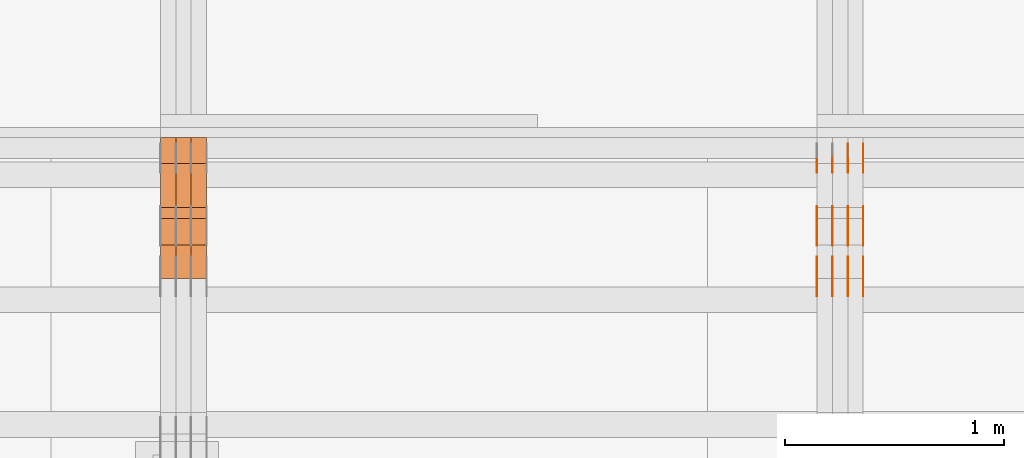
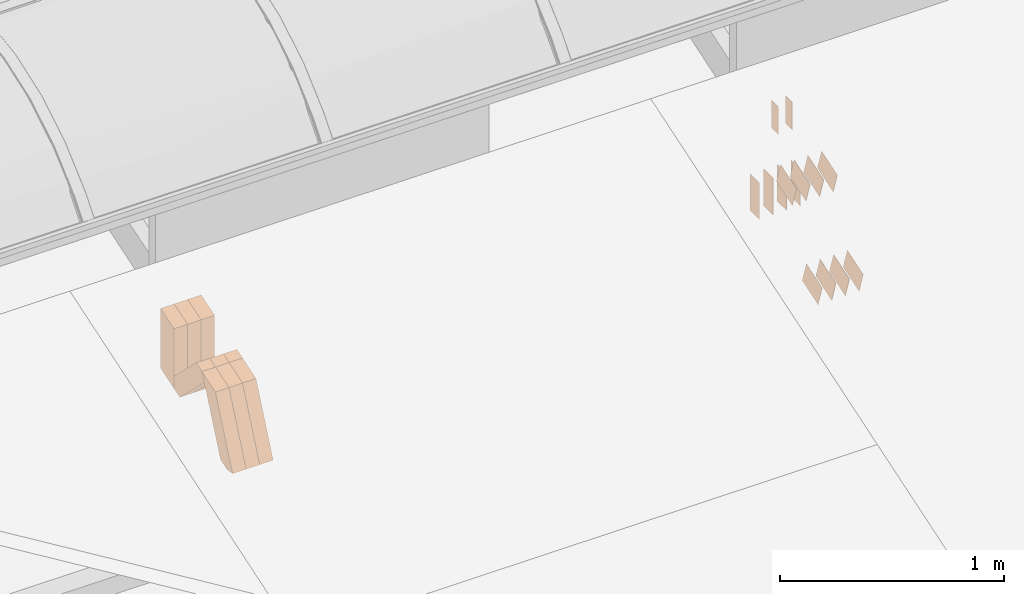
# One storey, part 97 of 385: 29 proxies.
"""IFC2X3 building model written with IfcOpenShell, lengths in millimetres."""

from ifc_helpers import new_model, entity, si_unit, converted_unit, derived_unit, direction, frame, frame_2d, origin, origin_2d_with_axis, place, context, subcontext, project, spatial, polyline, rectangle, outline, extrude, source, transform, mapped, material, type_object, type_shapes, element, save


model = new_model("IFC2X3")

# Units and contexts
model_context = context("Model", 3, precision=0.01, world=origin(), true_north=direction((6.12303176911189e-17, 1.0)))
body_context = subcontext(model_context, "Body", "Model", "MODEL_VIEW")
ifc_project = project(units=[si_unit("LENGTHUNIT", "METRE", prefix="MILLI"), si_unit("AREAUNIT", "SQUARE_METRE"), si_unit("VOLUMEUNIT", "CUBIC_METRE"), converted_unit("PLANEANGLEUNIT", "DEGREE", entity("IfcRatioMeasure", 0.0174532925199433), si_unit("PLANEANGLEUNIT", "RADIAN"), dimensions=[0, 0, 0, 0, 0, 0, 0]), si_unit("MASSUNIT", "GRAM", prefix="KILO"), derived_unit("MASSDENSITYUNIT", [(si_unit("MASSUNIT", "GRAM", prefix="KILO"), 1), (si_unit("LENGTHUNIT", "METRE"), -3)]), si_unit("TIMEUNIT", "SECOND"), si_unit("FREQUENCYUNIT", "HERTZ"), si_unit("THERMODYNAMICTEMPERATUREUNIT", "DEGREE_CELSIUS"), derived_unit("THERMALTRANSMITTANCEUNIT", [(si_unit("MASSUNIT", "GRAM", prefix="KILO"), 1), (si_unit("THERMODYNAMICTEMPERATUREUNIT", "KELVIN"), -1), (si_unit("TIMEUNIT", "SECOND"), -3)]), derived_unit("VOLUMETRICFLOWRATEUNIT", [(si_unit("LENGTHUNIT", "METRE"), 3), (si_unit("TIMEUNIT", "SECOND"), -1)]), si_unit("ELECTRICCURRENTUNIT", "AMPERE"), si_unit("ELECTRICVOLTAGEUNIT", "VOLT"), si_unit("POWERUNIT", "WATT"), si_unit("FORCEUNIT", "NEWTON", prefix="KILO"), si_unit("ILLUMINANCEUNIT", "LUX"), si_unit("LUMINOUSFLUXUNIT", "LUMEN"), si_unit("LUMINOUSINTENSITYUNIT", "CANDELA"), derived_unit("USERDEFINED", [(si_unit("MASSUNIT", "GRAM", prefix="KILO"), -1), (si_unit("LENGTHUNIT", "METRE"), -2), (si_unit("TIMEUNIT", "SECOND"), 3), (si_unit("LUMINOUSFLUXUNIT", "LUMEN"), 1)]), derived_unit("LINEARVELOCITYUNIT", [(si_unit("LENGTHUNIT", "METRE"), 1), (si_unit("TIMEUNIT", "SECOND"), -1)]), si_unit("PRESSUREUNIT", "PASCAL"), derived_unit("USERDEFINED", [(si_unit("LENGTHUNIT", "METRE"), -2), (si_unit("MASSUNIT", "GRAM", prefix="KILO"), 1), (si_unit("TIMEUNIT", "SECOND"), -2)])], contexts=[model_context])

# Site, building, storey
site_placement = place(None, origin())
site = spatial("IfcSite", under=ifc_project, at=site_placement, CompositionType="ELEMENT")
building_placement = place(site_placement, origin())
building = spatial("IfcBuilding", under=site, at=building_placement, CompositionType="ELEMENT")
storey_placement = place(building_placement, origin())
storey = spatial("IfcBuildingStorey", under=building, at=storey_placement, Name="Default", CompositionType="ELEMENT", Elevation=0.0)

# Proxies
ifc_material_1 = material(Name="IfcSurfaceStyle #209140")
building_element_proxy_type_1 = type_object("IfcBuildingElementProxyType", PredefinedType="NOTDEFINED", material=ifc_material_1)
shared_shape_1 = source(origin(), body_context, "Body", "SweptSolid", [
    extrude(rectangle(XDim=200.0, YDim=84.0, at=frame_2d((0.0, -7.105427357601e-15), x_axis=(1.0, 0.0))), frame((100.0, 42.0, 0.0), z_axis=(0.0, 0.0, 1.0), x_axis=(-1.0, 0.0, 0.0)), (0.0, 0.0, 1.0), 1.3),
])
type_shapes(building_element_proxy_type_1, [shared_shape_1])
proxy_1_placement = place(building_placement, frame((15386.3, 13702.0, 3651.4150390625), z_axis=(-1.0, 0.0, 0.0), x_axis=(0.0, 0.0, -1.0)))
element("IfcBuildingElementProxy", 1, at=proxy_1_placement, inside=storey, type_object=building_element_proxy_type_1, material=ifc_material_1, context=body_context, shape_type="MappedRepresentation", body=[
    mapped(shared_shape_1, transform((0.0, 0.0, 0.0), scale=1.0)),
])
ifc_material_2 = material(Name="IfcSurfaceStyle #209083")
building_element_proxy_type_2 = type_object("IfcBuildingElementProxyType", PredefinedType="NOTDEFINED", material=ifc_material_2)
shared_shape_2 = source(origin(), body_context, "Body", "SweptSolid", [
    extrude(rectangle(XDim=200.0, YDim=84.0, at=frame_2d((0.0, -7.105427357601e-15), x_axis=(1.0, 0.0))), frame((100.0, 42.0, 0.0), z_axis=(0.0, 0.0, 1.0), x_axis=(-1.0, 0.0, 0.0)), (0.0, 0.0, 1.0), 1.3),
])
type_shapes(building_element_proxy_type_2, [shared_shape_2])
proxy_2_placement = place(building_placement, frame((15315.0, 13702.0, 3651.4150390625), z_axis=(-1.0, 0.0, 0.0), x_axis=(0.0, 0.0, -1.0)))
element("IfcBuildingElementProxy", 2, at=proxy_2_placement, inside=storey, type_object=building_element_proxy_type_2, material=ifc_material_2, context=body_context, shape_type="MappedRepresentation", body=[
    mapped(shared_shape_2, transform((0.0, 0.0, 0.0), scale=1.0)),
])
ifc_material_3 = material(Name="IfcSurfaceStyle #209026")
building_element_proxy_type_3 = type_object("IfcBuildingElementProxyType", PredefinedType="NOTDEFINED", material=ifc_material_3)
shared_shape_3 = source(origin(), body_context, "Body", "SweptSolid", [
    extrude(rectangle(XDim=200.0, YDim=84.0, at=frame_2d((0.0, -7.105427357601e-15), x_axis=(1.0, 0.0))), frame((100.0, 42.0, 0.0), z_axis=(0.0, 0.0, 1.0), x_axis=(-1.0, 0.0, 0.0)), (0.0, 0.0, 1.0), 1.3),
])
type_shapes(building_element_proxy_type_3, [shared_shape_3])
proxy_3_placement = place(building_placement, frame((15316.3, 13702.0, 3651.4150390625), z_axis=(-1.0, 0.0, 0.0), x_axis=(0.0, 0.0, -1.0)))
element("IfcBuildingElementProxy", 3, at=proxy_3_placement, inside=storey, type_object=building_element_proxy_type_3, material=ifc_material_3, context=body_context, shape_type="MappedRepresentation", body=[
    mapped(shared_shape_3, transform((0.0, 0.0, 0.0), scale=1.0)),
])
ifc_material_4 = material(Name="IfcSurfaceStyle #208969")
building_element_proxy_type_4 = type_object("IfcBuildingElementProxyType", PredefinedType="NOTDEFINED", material=ifc_material_4)
shared_shape_4 = source(origin(), body_context, "Body", "SweptSolid", [
    extrude(rectangle(XDim=200.0, YDim=84.0, at=frame_2d((0.0, -7.105427357601e-15), x_axis=(1.0, 0.0))), frame((100.0, 42.0, 0.0), z_axis=(0.0, 0.0, 1.0), x_axis=(-1.0, 0.0, 0.0)), (0.0, 0.0, 1.0), 1.29999999999998),
])
type_shapes(building_element_proxy_type_4, [shared_shape_4])
proxy_4_placement = place(building_placement, frame((15245.0, 13702.0, 3651.4150390625), z_axis=(-1.0, 0.0, 0.0), x_axis=(0.0, 0.0, -1.0)))
element("IfcBuildingElementProxy", 4, at=proxy_4_placement, inside=storey, type_object=building_element_proxy_type_4, material=ifc_material_4, context=body_context, shape_type="MappedRepresentation", body=[
    mapped(shared_shape_4, transform((0.0, 0.0, 0.0), scale=1.0)),
])
ifc_material_5 = material(Name="IfcSurfaceStyle #208912")
building_element_proxy_type_5 = type_object("IfcBuildingElementProxyType", PredefinedType="NOTDEFINED", material=ifc_material_5)
shared_shape_5 = source(origin(), body_context, "Body", "SweptSolid", [
    extrude(rectangle(XDim=200.0, YDim=84.0, at=frame_2d((0.0, -7.105427357601e-15), x_axis=(1.0, 0.0))), frame((100.0, 42.0, 0.0), z_axis=(0.0, 0.0, 1.0), x_axis=(-1.0, 0.0, 0.0)), (0.0, 0.0, 1.0), 1.29999999999998),
])
type_shapes(building_element_proxy_type_5, [shared_shape_5])
proxy_5_placement = place(building_placement, frame((15246.3, 13702.0, 3651.4150390625), z_axis=(-1.0, 0.0, 0.0), x_axis=(0.0, 0.0, -1.0)))
element("IfcBuildingElementProxy", 5, at=proxy_5_placement, inside=storey, type_object=building_element_proxy_type_5, material=ifc_material_5, context=body_context, shape_type="MappedRepresentation", body=[
    mapped(shared_shape_5, transform((0.0, 0.0, 0.0), scale=1.0)),
])
ifc_material_6 = material(Name="IfcSurfaceStyle #208855")
building_element_proxy_type_6 = type_object("IfcBuildingElementProxyType", PredefinedType="NOTDEFINED", material=ifc_material_6)
shared_shape_6 = source(origin(), body_context, "Body", "SweptSolid", [
    extrude(rectangle(XDim=200.0, YDim=84.0, at=frame_2d((0.0, -7.105427357601e-15), x_axis=(1.0, 0.0))), frame((100.0, 42.0, 0.0), z_axis=(0.0, 0.0, 1.0), x_axis=(-1.0, 0.0, 0.0)), (0.0, 0.0, 1.0), 1.29999999999999),
])
type_shapes(building_element_proxy_type_6, [shared_shape_6])
proxy_6_placement = place(building_placement, frame((15175.0, 13702.0, 3651.4150390625), z_axis=(-1.0, 0.0, 0.0), x_axis=(0.0, 0.0, -1.0)))
element("IfcBuildingElementProxy", 6, at=proxy_6_placement, inside=storey, type_object=building_element_proxy_type_6, material=ifc_material_6, context=body_context, shape_type="MappedRepresentation", body=[
    mapped(shared_shape_6, transform((0.0, 0.0, 0.0), scale=1.0)),
])
ifc_material_7 = material(Name="IfcSurfaceStyle #208798")
building_element_proxy_type_7 = type_object("IfcBuildingElementProxyType", PredefinedType="NOTDEFINED", material=ifc_material_7)
shared_shape_7 = source(origin(), body_context, "Body", "SweptSolid", [
    extrude(outline(polyline([(-75.0003398116828, -59.9998507501386), (75.0003249421766, -59.9998507501386), (75.0003398116837, 59.9998507501387), (-75.0003249421775, 59.9998507501387), (-75.0003398116828, -59.9998507501386)])), frame((75.0003398116837, 60.0000773549637, 0.0), z_axis=(0.0, 0.0, 1.0), x_axis=(-1.0, 0.0, 0.0)), (0.0, 0.0, 1.0), 1.3),
])
type_shapes(building_element_proxy_type_7, [shared_shape_7])
proxy_7_placement = place(building_placement, frame((15386.3, 13054.73046875, 3417.8388671875), z_axis=(-1.0, 0.0, 0.0), x_axis=(0.0, 0.951056516295124, 0.309016994375039)))
element("IfcBuildingElementProxy", 7, at=proxy_7_placement, inside=storey, type_object=building_element_proxy_type_7, material=ifc_material_7, context=body_context, shape_type="MappedRepresentation", body=[
    mapped(shared_shape_7, transform((0.0, 0.0, 0.0), scale=1.0)),
])
ifc_material_8 = material(Name="IfcSurfaceStyle #208741")
building_element_proxy_type_8 = type_object("IfcBuildingElementProxyType", PredefinedType="NOTDEFINED", material=ifc_material_8)
shared_shape_8 = source(origin(), body_context, "Body", "SweptSolid", [
    extrude(outline(polyline([(-75.0003398116828, -59.9998507501386), (75.0003249421766, -59.9998507501386), (75.0003398116837, 59.9998507501387), (-75.0003249421775, 59.9998507501387), (-75.0003398116828, -59.9998507501386)])), frame((75.0003398116837, 60.0000773549637, 0.0), z_axis=(0.0, 0.0, 1.0), x_axis=(-1.0, 0.0, 0.0)), (0.0, 0.0, 1.0), 1.3),
])
type_shapes(building_element_proxy_type_8, [shared_shape_8])
proxy_8_placement = place(building_placement, frame((15315.0, 13054.73046875, 3417.8388671875), z_axis=(-1.0, 0.0, 0.0), x_axis=(0.0, 0.951056516295124, 0.309016994375039)))
element("IfcBuildingElementProxy", 8, at=proxy_8_placement, inside=storey, type_object=building_element_proxy_type_8, material=ifc_material_8, context=body_context, shape_type="MappedRepresentation", body=[
    mapped(shared_shape_8, transform((0.0, 0.0, 0.0), scale=1.0)),
])
ifc_material_9 = material(Name="IfcSurfaceStyle #208684")
building_element_proxy_type_9 = type_object("IfcBuildingElementProxyType", PredefinedType="NOTDEFINED", material=ifc_material_9)
shared_shape_9 = source(origin(), body_context, "Body", "SweptSolid", [
    extrude(outline(polyline([(-75.0003398116828, -59.9998507501386), (75.0003249421766, -59.9998507501386), (75.0003398116837, 59.9998507501387), (-75.0003249421775, 59.9998507501387), (-75.0003398116828, -59.9998507501386)])), frame((75.0003398116837, 60.0000773549637, 0.0), z_axis=(0.0, 0.0, 1.0), x_axis=(-1.0, 0.0, 0.0)), (0.0, 0.0, 1.0), 1.3),
])
type_shapes(building_element_proxy_type_9, [shared_shape_9])
proxy_9_placement = place(building_placement, frame((15316.3, 13054.73046875, 3417.8388671875), z_axis=(-1.0, 0.0, 0.0), x_axis=(0.0, 0.951056516295124, 0.309016994375039)))
element("IfcBuildingElementProxy", 9, at=proxy_9_placement, inside=storey, type_object=building_element_proxy_type_9, material=ifc_material_9, context=body_context, shape_type="MappedRepresentation", body=[
    mapped(shared_shape_9, transform((0.0, 0.0, 0.0), scale=1.0)),
])
ifc_material_10 = material(Name="IfcSurfaceStyle #208627")
building_element_proxy_type_10 = type_object("IfcBuildingElementProxyType", PredefinedType="NOTDEFINED", material=ifc_material_10)
shared_shape_10 = source(origin(), body_context, "Body", "SweptSolid", [
    extrude(outline(polyline([(-75.0003398116828, -59.9998507501386), (75.0003249421766, -59.9998507501386), (75.0003398116837, 59.9998507501387), (-75.0003249421775, 59.9998507501387), (-75.0003398116828, -59.9998507501386)])), frame((75.0003398116837, 60.0000773549637, 0.0), z_axis=(0.0, 0.0, 1.0), x_axis=(-1.0, 0.0, 0.0)), (0.0, 0.0, 1.0), 1.29999999999999),
])
type_shapes(building_element_proxy_type_10, [shared_shape_10])
proxy_10_placement = place(building_placement, frame((15245.0, 13054.73046875, 3417.8388671875), z_axis=(-1.0, 0.0, 0.0), x_axis=(0.0, 0.951056516295124, 0.309016994375039)))
element("IfcBuildingElementProxy", 10, at=proxy_10_placement, inside=storey, type_object=building_element_proxy_type_10, material=ifc_material_10, context=body_context, shape_type="MappedRepresentation", body=[
    mapped(shared_shape_10, transform((0.0, 0.0, 0.0), scale=1.0)),
])
ifc_material_11 = material(Name="IfcSurfaceStyle #208570")
building_element_proxy_type_11 = type_object("IfcBuildingElementProxyType", PredefinedType="NOTDEFINED", material=ifc_material_11)
shared_shape_11 = source(origin(), body_context, "Body", "SweptSolid", [
    extrude(outline(polyline([(-75.0003398116828, -59.9998507501386), (75.0003249421766, -59.9998507501386), (75.0003398116837, 59.9998507501387), (-75.0003249421775, 59.9998507501387), (-75.0003398116828, -59.9998507501386)])), frame((75.0003398116837, 60.0000773549637, 0.0), z_axis=(0.0, 0.0, 1.0), x_axis=(-1.0, 0.0, 0.0)), (0.0, 0.0, 1.0), 1.29999999999999),
])
type_shapes(building_element_proxy_type_11, [shared_shape_11])
proxy_11_placement = place(building_placement, frame((15246.3, 13054.73046875, 3417.8388671875), z_axis=(-1.0, 0.0, 0.0), x_axis=(0.0, 0.951056516295124, 0.309016994375039)))
element("IfcBuildingElementProxy", 11, at=proxy_11_placement, inside=storey, type_object=building_element_proxy_type_11, material=ifc_material_11, context=body_context, shape_type="MappedRepresentation", body=[
    mapped(shared_shape_11, transform((0.0, 0.0, 0.0), scale=1.0)),
])
ifc_material_12 = material(Name="IfcSurfaceStyle #208513")
building_element_proxy_type_12 = type_object("IfcBuildingElementProxyType", PredefinedType="NOTDEFINED", material=ifc_material_12)
shared_shape_12 = source(origin(), body_context, "Body", "SweptSolid", [
    extrude(outline(polyline([(-75.0003398116828, -59.9998507501386), (75.0003249421766, -59.9998507501386), (75.0003398116837, 59.9998507501387), (-75.0003249421775, 59.9998507501387), (-75.0003398116828, -59.9998507501386)])), frame((75.0003398116837, 60.0000773549637, 0.0), z_axis=(0.0, 0.0, 1.0), x_axis=(-1.0, 0.0, 0.0)), (0.0, 0.0, 1.0), 1.29999999999999),
])
type_shapes(building_element_proxy_type_12, [shared_shape_12])
proxy_12_placement = place(building_placement, frame((15175.0, 13054.73046875, 3417.8388671875), z_axis=(-1.0, 0.0, 0.0), x_axis=(0.0, 0.951056516295124, 0.309016994375039)))
element("IfcBuildingElementProxy", 12, at=proxy_12_placement, inside=storey, type_object=building_element_proxy_type_12, material=ifc_material_12, context=body_context, shape_type="MappedRepresentation", body=[
    mapped(shared_shape_12, transform((0.0, 0.0, 0.0), scale=1.0)),
])
ifc_material_13 = material(Name="IfcSurfaceStyle #200932")
building_element_proxy_type_13 = type_object("IfcBuildingElementProxyType", PredefinedType="NOTDEFINED", material=ifc_material_13)
shared_shape_13 = source(origin(), body_context, "Body", "SweptSolid", [
    extrude(outline(polyline([(-74.999875428623, -60.0000016373506), (74.9998605591059, -60.0000016373506), (74.9998754286239, 60.0000016373506), (-74.9998605591068, 60.0000016373506), (-74.999875428623, -60.0000016373506)])), frame((75.0002691827262, 60.0000190504561, 0.0), z_axis=(0.0, 0.0, 1.0), x_axis=(-1.0, 0.0, 0.0)), (0.0, 0.0, 1.0), 1.3),
])
type_shapes(building_element_proxy_type_13, [shared_shape_13])
proxy_13_placement = place(building_placement, frame((15386.3, 13285.0865109705, 3819.37496637467), z_axis=(-1.0, 0.0, 0.0), x_axis=(0.0, 0.951056516295154, 0.309016994374948)))
element("IfcBuildingElementProxy", 13, at=proxy_13_placement, inside=storey, type_object=building_element_proxy_type_13, material=ifc_material_13, context=body_context, shape_type="MappedRepresentation", body=[
    mapped(shared_shape_13, transform((0.0, 0.0, 0.0), scale=1.0)),
])
ifc_material_14 = material(Name="IfcSurfaceStyle #200875")
building_element_proxy_type_14 = type_object("IfcBuildingElementProxyType", PredefinedType="NOTDEFINED", material=ifc_material_14)
shared_shape_14 = source(origin(), body_context, "Body", "SweptSolid", [
    extrude(outline(polyline([(-74.999875428623, -60.0000016373506), (74.9998605591059, -60.0000016373506), (74.9998754286239, 60.0000016373506), (-74.9998605591068, 60.0000016373506), (-74.999875428623, -60.0000016373506)])), frame((75.0002691827262, 60.0000190504561, 0.0), z_axis=(0.0, 0.0, 1.0), x_axis=(-1.0, 0.0, 0.0)), (0.0, 0.0, 1.0), 1.3),
])
type_shapes(building_element_proxy_type_14, [shared_shape_14])
proxy_14_placement = place(building_placement, frame((15315.0, 13285.0865109705, 3819.37496637467), z_axis=(-1.0, 0.0, 0.0), x_axis=(0.0, 0.951056516295154, 0.309016994374948)))
element("IfcBuildingElementProxy", 14, at=proxy_14_placement, inside=storey, type_object=building_element_proxy_type_14, material=ifc_material_14, context=body_context, shape_type="MappedRepresentation", body=[
    mapped(shared_shape_14, transform((0.0, 0.0, 0.0), scale=1.0)),
])
ifc_material_15 = material(Name="IfcSurfaceStyle #200818")
building_element_proxy_type_15 = type_object("IfcBuildingElementProxyType", PredefinedType="NOTDEFINED", material=ifc_material_15)
shared_shape_15 = source(origin(), body_context, "Body", "SweptSolid", [
    extrude(outline(polyline([(-74.999875428623, -60.0000016373506), (74.9998605591059, -60.0000016373506), (74.9998754286239, 60.0000016373506), (-74.9998605591068, 60.0000016373506), (-74.999875428623, -60.0000016373506)])), frame((75.0002691827262, 60.0000190504561, 0.0), z_axis=(0.0, 0.0, 1.0), x_axis=(-1.0, 0.0, 0.0)), (0.0, 0.0, 1.0), 1.3),
])
type_shapes(building_element_proxy_type_15, [shared_shape_15])
proxy_15_placement = place(building_placement, frame((15316.3, 13285.0865109705, 3819.37496637467), z_axis=(-1.0, 0.0, 0.0), x_axis=(0.0, 0.951056516295154, 0.309016994374948)))
element("IfcBuildingElementProxy", 15, at=proxy_15_placement, inside=storey, type_object=building_element_proxy_type_15, material=ifc_material_15, context=body_context, shape_type="MappedRepresentation", body=[
    mapped(shared_shape_15, transform((0.0, 0.0, 0.0), scale=1.0)),
])
ifc_material_16 = material(Name="IfcSurfaceStyle #200761")
building_element_proxy_type_16 = type_object("IfcBuildingElementProxyType", PredefinedType="NOTDEFINED", material=ifc_material_16)
shared_shape_16 = source(origin(), body_context, "Body", "SweptSolid", [
    extrude(outline(polyline([(-74.999875428623, -60.0000016373506), (74.9998605591059, -60.0000016373506), (74.9998754286239, 60.0000016373506), (-74.9998605591068, 60.0000016373506), (-74.999875428623, -60.0000016373506)])), frame((75.0002691827262, 60.0000190504561, 0.0), z_axis=(0.0, 0.0, 1.0), x_axis=(-1.0, 0.0, 0.0)), (0.0, 0.0, 1.0), 1.29999999999999),
])
type_shapes(building_element_proxy_type_16, [shared_shape_16])
proxy_16_placement = place(building_placement, frame((15245.0, 13285.0865109705, 3819.37496637467), z_axis=(-1.0, 0.0, 0.0), x_axis=(0.0, 0.951056516295154, 0.309016994374948)))
element("IfcBuildingElementProxy", 16, at=proxy_16_placement, inside=storey, type_object=building_element_proxy_type_16, material=ifc_material_16, context=body_context, shape_type="MappedRepresentation", body=[
    mapped(shared_shape_16, transform((0.0, 0.0, 0.0), scale=1.0)),
])
ifc_material_17 = material(Name="IfcSurfaceStyle #200704")
building_element_proxy_type_17 = type_object("IfcBuildingElementProxyType", PredefinedType="NOTDEFINED", material=ifc_material_17)
shared_shape_17 = source(origin(), body_context, "Body", "SweptSolid", [
    extrude(outline(polyline([(-74.999875428623, -60.0000016373506), (74.9998605591059, -60.0000016373506), (74.9998754286239, 60.0000016373506), (-74.9998605591068, 60.0000016373506), (-74.999875428623, -60.0000016373506)])), frame((75.0002691827262, 60.0000190504561, 0.0), z_axis=(0.0, 0.0, 1.0), x_axis=(-1.0, 0.0, 0.0)), (0.0, 0.0, 1.0), 1.29999999999999),
])
type_shapes(building_element_proxy_type_17, [shared_shape_17])
proxy_17_placement = place(building_placement, frame((15246.3, 13285.0865109705, 3819.37496637467), z_axis=(-1.0, 0.0, 0.0), x_axis=(0.0, 0.951056516295154, 0.309016994374948)))
element("IfcBuildingElementProxy", 17, at=proxy_17_placement, inside=storey, type_object=building_element_proxy_type_17, material=ifc_material_17, context=body_context, shape_type="MappedRepresentation", body=[
    mapped(shared_shape_17, transform((0.0, 0.0, 0.0), scale=1.0)),
])
ifc_material_18 = material(Name="IfcSurfaceStyle #200647")
building_element_proxy_type_18 = type_object("IfcBuildingElementProxyType", PredefinedType="NOTDEFINED", material=ifc_material_18)
shared_shape_18 = source(origin(), body_context, "Body", "SweptSolid", [
    extrude(outline(polyline([(-74.999875428623, -60.0000016373506), (74.9998605591059, -60.0000016373506), (74.9998754286239, 60.0000016373506), (-74.9998605591068, 60.0000016373506), (-74.999875428623, -60.0000016373506)])), frame((75.0002691827262, 60.0000190504561, 0.0), z_axis=(0.0, 0.0, 1.0), x_axis=(-1.0, 0.0, 0.0)), (0.0, 0.0, 1.0), 1.29999999999999),
])
type_shapes(building_element_proxy_type_18, [shared_shape_18])
proxy_18_placement = place(building_placement, frame((15175.0, 13285.0865109705, 3819.37496637467), z_axis=(-1.0, 0.0, 0.0), x_axis=(0.0, 0.951056516295154, 0.309016994374948)))
element("IfcBuildingElementProxy", 18, at=proxy_18_placement, inside=storey, type_object=building_element_proxy_type_18, material=ifc_material_18, context=body_context, shape_type="MappedRepresentation", body=[
    mapped(shared_shape_18, transform((0.0, 0.0, 0.0), scale=1.0)),
])
ifc_material_19 = material(Name="IfcSurfaceStyle #200248")
building_element_proxy_type_19 = type_object("IfcBuildingElementProxyType", PredefinedType="NOTDEFINED", material=ifc_material_19)
shared_shape_19 = source(origin(), body_context, "Body", "SweptSolid", [
    extrude(rectangle(XDim=150.0, YDim=60.0, at=origin_2d_with_axis()), frame((75.0000705696166, 30.0, 0.0), z_axis=(0.0, 0.0, 1.0), x_axis=(-1.0, 0.0, 0.0)), (0.0, 0.0, 1.0), 1.3),
])
type_shapes(building_element_proxy_type_19, [shared_shape_19])
proxy_19_placement = place(building_placement, frame((15386.3, 13750.0, 3972.59919166337), z_axis=(-1.0, 0.0, 0.0), x_axis=(0.0, 0.0, -1.0)))
element("IfcBuildingElementProxy", 19, at=proxy_19_placement, inside=storey, type_object=building_element_proxy_type_19, material=ifc_material_19, context=body_context, shape_type="MappedRepresentation", body=[
    mapped(shared_shape_19, transform((0.0, 0.0, 0.0), scale=1.0)),
])
ifc_material_20 = material(Name="IfcSurfaceStyle #200191")
building_element_proxy_type_20 = type_object("IfcBuildingElementProxyType", PredefinedType="NOTDEFINED", material=ifc_material_20)
shared_shape_20 = source(origin(), body_context, "Body", "SweptSolid", [
    extrude(rectangle(XDim=150.0, YDim=60.0, at=origin_2d_with_axis()), frame((75.0000705696166, 30.0, 0.0), z_axis=(0.0, 0.0, 1.0), x_axis=(-1.0, 0.0, 0.0)), (0.0, 0.0, 1.0), 1.3),
])
type_shapes(building_element_proxy_type_20, [shared_shape_20])
proxy_20_placement = place(building_placement, frame((15315.0, 13750.0, 3972.59919166337), z_axis=(-1.0, 0.0, 0.0), x_axis=(0.0, 0.0, -1.0)))
element("IfcBuildingElementProxy", 20, at=proxy_20_placement, inside=storey, type_object=building_element_proxy_type_20, material=ifc_material_20, context=body_context, shape_type="MappedRepresentation", body=[
    mapped(shared_shape_20, transform((0.0, 0.0, 0.0), scale=1.0)),
])
ifc_material_21 = material(Name="IfcSurfaceStyle #156330")
building_element_proxy_type_21 = type_object("IfcBuildingElementProxyType", Name="T1-W49 156328", PredefinedType="NOTDEFINED", material=ifc_material_21)
shared_shape_21 = source(origin(), body_context, "Body", "SweptSolid", [
    extrude(outline(polyline([(-155.175867306415, -47.4997478409253), (152.310664695054, -47.4997478409253), (170.496756790954, -6.14570120142345e-05), (145.70957993751, 47.4998092979374), (-133.37808995724, 47.4998092979373), (-179.963044159863, -6.14570120298391e-05), (-155.175867306415, -47.4997478409253)])), frame((170.496756790954, 47.5001152140455, 0.0), z_axis=(0.0, 0.0, 1.0), x_axis=(-1.0, 0.0, 0.0)), (0.0, 0.0, 1.0), 70.0),
])
type_shapes(building_element_proxy_type_21, [shared_shape_21])
proxy_21_placement = place(building_placement, frame((12385.0, 13443.048524104, 3830.71841973934), z_axis=(-1.0, 0.0, 0.0), x_axis=(0.0, 0.713950095632063, -0.700196587357413)))
element("IfcBuildingElementProxy", 21, at=proxy_21_placement, inside=storey, type_object=building_element_proxy_type_21, material=ifc_material_21, Name="T1-W49", context=body_context, shape_type="MappedRepresentation", body=[
    mapped(shared_shape_21, transform((0.0, 0.0, 0.0), scale=1.0)),
])
ifc_material_22 = material(Name="IfcSurfaceStyle #156255")
building_element_proxy_type_22 = type_object("IfcBuildingElementProxyType", Name="T1-W49 156253", PredefinedType="NOTDEFINED", material=ifc_material_22)
shared_shape_22 = source(origin(), body_context, "Body", "SweptSolid", [
    extrude(outline(polyline([(-155.175867306415, -47.4997478409253), (152.310664695054, -47.4997478409253), (170.496756790954, -6.14570120142345e-05), (145.70957993751, 47.4998092979374), (-133.37808995724, 47.4998092979373), (-179.963044159863, -6.14570120298391e-05), (-155.175867306415, -47.4997478409253)])), frame((170.496756790954, 47.5001152140455, 0.0), z_axis=(0.0, 0.0, 1.0), x_axis=(-1.0, 0.0, 0.0)), (0.0, 0.0, 1.0), 70.0),
])
type_shapes(building_element_proxy_type_22, [shared_shape_22])
proxy_22_placement = place(building_placement, frame((12315.0, 13443.048524104, 3830.71841973934), z_axis=(-1.0, 0.0, 0.0), x_axis=(0.0, 0.713950095632063, -0.700196587357413)))
element("IfcBuildingElementProxy", 22, at=proxy_22_placement, inside=storey, type_object=building_element_proxy_type_22, material=ifc_material_22, Name="T1-W49", context=body_context, shape_type="MappedRepresentation", body=[
    mapped(shared_shape_22, transform((0.0, 0.0, 0.0), scale=1.0)),
])
ifc_material_23 = material(Name="IfcSurfaceStyle #156180")
building_element_proxy_type_23 = type_object("IfcBuildingElementProxyType", Name="T1-W49 156178", PredefinedType="NOTDEFINED", material=ifc_material_23)
shared_shape_23 = source(origin(), body_context, "Body", "SweptSolid", [
    extrude(outline(polyline([(-155.175867306415, -47.4997478409253), (152.310664695054, -47.4997478409253), (170.496756790954, -6.14570120142345e-05), (145.70957993751, 47.4998092979374), (-133.37808995724, 47.4998092979373), (-179.963044159863, -6.14570120298391e-05), (-155.175867306415, -47.4997478409253)])), frame((170.496756790954, 47.5001152140455, 0.0), z_axis=(0.0, 0.0, 1.0), x_axis=(-1.0, 0.0, 0.0)), (0.0, 0.0, 1.0), 70.0),
])
type_shapes(building_element_proxy_type_23, [shared_shape_23])
proxy_23_placement = place(building_placement, frame((12245.0, 13443.048524104, 3830.71841973934), z_axis=(-1.0, 0.0, 0.0), x_axis=(0.0, 0.713950095632063, -0.700196587357413)))
element("IfcBuildingElementProxy", 23, at=proxy_23_placement, inside=storey, type_object=building_element_proxy_type_23, material=ifc_material_23, Name="T1-W49", context=body_context, shape_type="MappedRepresentation", body=[
    mapped(shared_shape_23, transform((0.0, 0.0, 0.0), scale=1.0)),
])
ifc_material_24 = material(Name="IfcSurfaceStyle #155880")
building_element_proxy_type_24 = type_object("IfcBuildingElementProxyType", Name="T1-W1 155878", PredefinedType="NOTDEFINED", material=ifc_material_24)
shared_shape_24 = source(origin(), body_context, "Body", "SweptSolid", [
    extrude(outline(polyline([(-182.839782714844, -60.0), (143.849426269531, -60.0), (182.839660644531, 60.0), (-143.849304199219, 60.0), (-182.839782714844, -60.0)])), frame((182.839674685549, 60.0, 0.0), z_axis=(0.0, 0.0, 1.0), x_axis=(-1.0, 0.0, 0.0)), (0.0, 0.0, 1.0), 70.0),
])
type_shapes(building_element_proxy_type_24, [shared_shape_24])
proxy_24_placement = place(building_placement, frame((12385.0, 13660.0, 3551.41502502148), z_axis=(-1.0, 0.0, 0.0), x_axis=(0.0, 0.0, 1.0)))
element("IfcBuildingElementProxy", 24, at=proxy_24_placement, inside=storey, type_object=building_element_proxy_type_24, material=ifc_material_24, Name="T1-W1", context=body_context, shape_type="MappedRepresentation", body=[
    mapped(shared_shape_24, transform((0.0, 0.0, 0.0), scale=1.0)),
])
ifc_material_25 = material(Name="IfcSurfaceStyle #155823")
building_element_proxy_type_25 = type_object("IfcBuildingElementProxyType", Name="T1-W1 155821", PredefinedType="NOTDEFINED", material=ifc_material_25)
shared_shape_25 = source(origin(), body_context, "Body", "SweptSolid", [
    extrude(outline(polyline([(-182.839782714844, -60.0), (143.849426269531, -60.0), (182.839660644531, 60.0), (-143.849304199219, 60.0), (-182.839782714844, -60.0)])), frame((182.839674685549, 60.0, 0.0), z_axis=(0.0, 0.0, 1.0), x_axis=(-1.0, 0.0, 0.0)), (0.0, 0.0, 1.0), 70.0),
])
type_shapes(building_element_proxy_type_25, [shared_shape_25])
proxy_25_placement = place(building_placement, frame((12315.0, 13660.0, 3551.41502502148), z_axis=(-1.0, 0.0, 0.0), x_axis=(0.0, 0.0, 1.0)))
element("IfcBuildingElementProxy", 25, at=proxy_25_placement, inside=storey, type_object=building_element_proxy_type_25, material=ifc_material_25, Name="T1-W1", context=body_context, shape_type="MappedRepresentation", body=[
    mapped(shared_shape_25, transform((0.0, 0.0, 0.0), scale=1.0)),
])
ifc_material_26 = material(Name="IfcSurfaceStyle #155766")
building_element_proxy_type_26 = type_object("IfcBuildingElementProxyType", Name="T1-W1 155764", PredefinedType="NOTDEFINED", material=ifc_material_26)
shared_shape_26 = source(origin(), body_context, "Body", "SweptSolid", [
    extrude(outline(polyline([(-182.839782714844, -60.0), (143.849426269531, -60.0), (182.839660644531, 60.0), (-143.849304199219, 60.0), (-182.839782714844, -60.0)])), frame((182.839674685549, 60.0, 0.0), z_axis=(0.0, 0.0, 1.0), x_axis=(-1.0, 0.0, 0.0)), (0.0, 0.0, 1.0), 70.0),
])
type_shapes(building_element_proxy_type_26, [shared_shape_26])
proxy_26_placement = place(building_placement, frame((12245.0, 13660.0, 3551.41502502148), z_axis=(-1.0, 0.0, 0.0), x_axis=(0.0, 0.0, 1.0)))
element("IfcBuildingElementProxy", 26, at=proxy_26_placement, inside=storey, type_object=building_element_proxy_type_26, material=ifc_material_26, Name="T1-W1", context=body_context, shape_type="MappedRepresentation", body=[
    mapped(shared_shape_26, transform((0.0, 0.0, 0.0), scale=1.0)),
])
ifc_material_27 = material(Name="IfcSurfaceStyle #155340")
building_element_proxy_type_27 = type_object("IfcBuildingElementProxyType", Name="T1-W42 155338", PredefinedType="NOTDEFINED", material=ifc_material_27)
shared_shape_27 = source(origin(), body_context, "Body", "SweptSolid", [
    extrude(outline(polyline([(-284.837590197601, -47.4997543607933), (129.95880168156, -47.4997543607933), (171.972324990451, 0.000162623346093338), (183.717007105413, 47.4996730491203), (-200.810543579822, 47.4996730491203), (-284.837590197601, -47.4997543607933)])), frame((183.717155718752, 47.4999821655365, 0.0), z_axis=(0.0, 0.0, 1.0), x_axis=(-1.0, 0.0, 0.0)), (0.0, 0.0, 1.0), 70.0),
])
type_shapes(building_element_proxy_type_27, [shared_shape_27])
proxy_27_placement = place(building_placement, frame((12385.0, 13135.8834463264, 3404.958483022), z_axis=(-1.0, 0.0, 0.0), x_axis=(0.0, 0.398630596470292, 0.917111578575769)))
element("IfcBuildingElementProxy", 27, at=proxy_27_placement, inside=storey, type_object=building_element_proxy_type_27, material=ifc_material_27, Name="T1-W42", context=body_context, shape_type="MappedRepresentation", body=[
    mapped(shared_shape_27, transform((0.0, 0.0, 0.0), scale=1.0)),
])
ifc_material_28 = material(Name="IfcSurfaceStyle #155274")
building_element_proxy_type_28 = type_object("IfcBuildingElementProxyType", Name="T1-W42 155272", PredefinedType="NOTDEFINED", material=ifc_material_28)
shared_shape_28 = source(origin(), body_context, "Body", "SweptSolid", [
    extrude(outline(polyline([(-284.837590197601, -47.4997543607933), (129.95880168156, -47.4997543607933), (171.972324990451, 0.000162623346093338), (183.717007105413, 47.4996730491203), (-200.810543579822, 47.4996730491203), (-284.837590197601, -47.4997543607933)])), frame((183.717155718752, 47.4999821655365, 0.0), z_axis=(0.0, 0.0, 1.0), x_axis=(-1.0, 0.0, 0.0)), (0.0, 0.0, 1.0), 70.0),
])
type_shapes(building_element_proxy_type_28, [shared_shape_28])
proxy_28_placement = place(building_placement, frame((12315.0, 13135.8834463264, 3404.958483022), z_axis=(-1.0, 0.0, 0.0), x_axis=(0.0, 0.398630596470292, 0.917111578575769)))
element("IfcBuildingElementProxy", 28, at=proxy_28_placement, inside=storey, type_object=building_element_proxy_type_28, material=ifc_material_28, Name="T1-W42", context=body_context, shape_type="MappedRepresentation", body=[
    mapped(shared_shape_28, transform((0.0, 0.0, 0.0), scale=1.0)),
])
ifc_material_29 = material(Name="IfcSurfaceStyle #155208")
building_element_proxy_type_29 = type_object("IfcBuildingElementProxyType", Name="T1-W42 155206", PredefinedType="NOTDEFINED", material=ifc_material_29)
shared_shape_29 = source(origin(), body_context, "Body", "SweptSolid", [
    extrude(outline(polyline([(-284.837590197601, -47.4997543607933), (129.95880168156, -47.4997543607933), (171.972324990451, 0.000162623346093338), (183.717007105413, 47.4996730491203), (-200.810543579822, 47.4996730491203), (-284.837590197601, -47.4997543607933)])), frame((183.717155718752, 47.4999821655365, 0.0), z_axis=(0.0, 0.0, 1.0), x_axis=(-1.0, 0.0, 0.0)), (0.0, 0.0, 1.0), 70.0),
])
type_shapes(building_element_proxy_type_29, [shared_shape_29])
proxy_29_placement = place(building_placement, frame((12245.0, 13135.8834463264, 3404.958483022), z_axis=(-1.0, 0.0, 0.0), x_axis=(0.0, 0.398630596470292, 0.917111578575769)))
element("IfcBuildingElementProxy", 29, at=proxy_29_placement, inside=storey, type_object=building_element_proxy_type_29, material=ifc_material_29, Name="T1-W42", context=body_context, shape_type="MappedRepresentation", body=[
    mapped(shared_shape_29, transform((0.0, 0.0, 0.0), scale=1.0)),
])

save(model, "model.ifc")
